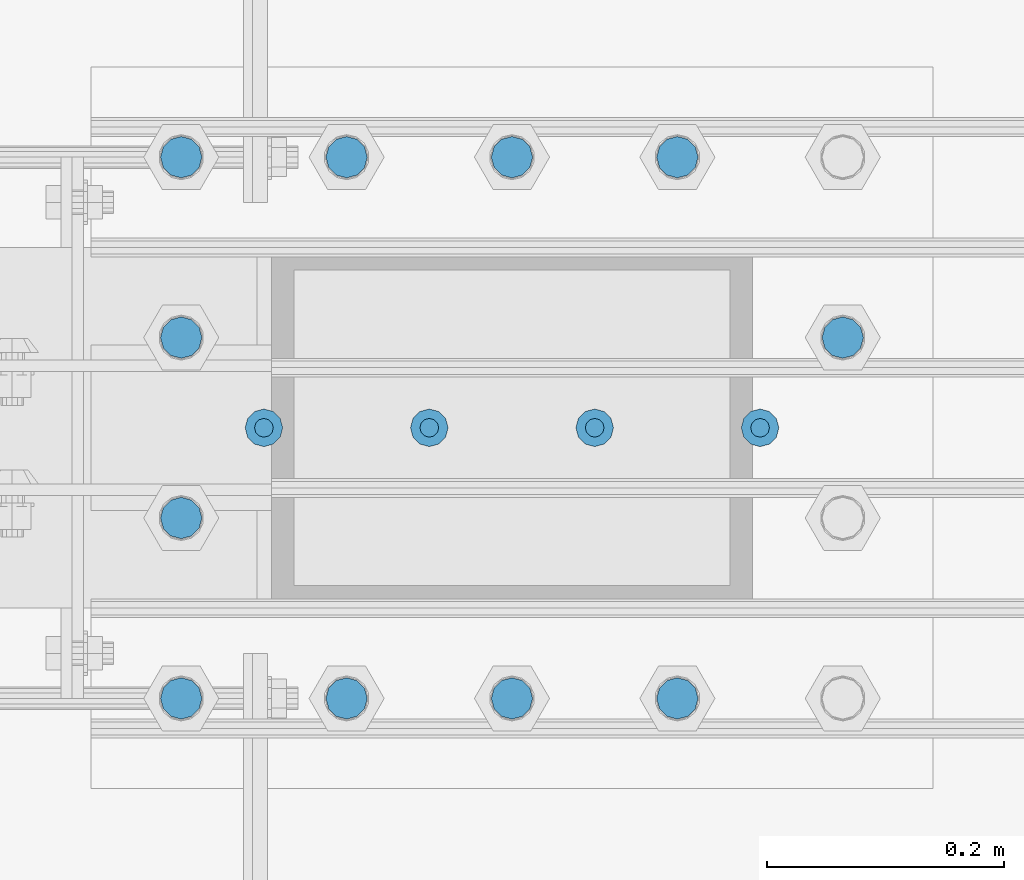
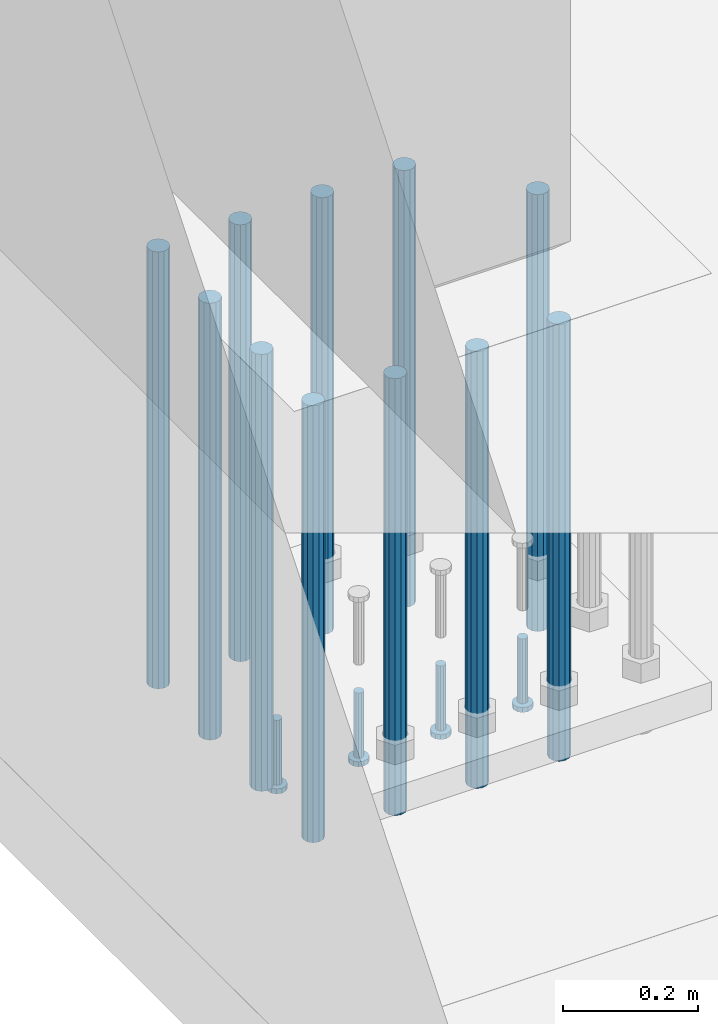
# One storey, part 1097 of 1876: 15 beams, 1 element without a shape of its own.
"""IFC2X3 building model written with IfcOpenShell, lengths in millimetres."""

import ifcopenshell
import ifcopenshell.guid

model = None  # the IFC model being written
_history = None  # IfcOwnerHistory: only IFC2X3 demands one
_inside = {}  # id of a spatial element -> (the spatial element, [elements in it])
_under = {}  # id of a project, library or spatial element -> (it, [spatial elements below it])
_declared = {}  # id of a project -> (the project, [libraries it declares])
_typed = {}  # id of a type object -> (the type object, [elements of that type])
_made_of = {}  # id of a material, layer set ... -> (it, [elements and type objects made of it])


def new_model(schema):
    """Start an empty IFC model of exactly this schema.

    Asked for "IFC4X3", IfcOpenShell would pick the latest addendum, in which some entities
    have other attributes; the version numbers below select the first issue.
    IFC2X3 requires an IfcOwnerHistory on every rooted entity: one is made here for all.
    """
    global model, _history
    if schema == "IFC4X3":
        model = ifcopenshell.file(schema_version=(4, 3, 0, 0))
    else:
        model = ifcopenshell.file(schema=schema)
    _inside.clear()
    _under.clear()
    _declared.clear()
    _typed.clear()
    _made_of.clear()
    _history = None
    if model.schema == "IFC2X3":
        org = make("IfcOrganization", Name="unknown")
        user = make(
            "IfcPersonAndOrganization",
            ThePerson=make("IfcPerson", FamilyName="unknown"),
            TheOrganization=org,
        )
        app = make(
            "IfcApplication",
            ApplicationDeveloper=org,
            Version="unknown",
            ApplicationFullName="unknown",
            ApplicationIdentifier="unknown",
        )
        _history = make(
            "IfcOwnerHistory",
            OwningUser=user,
            OwningApplication=app,
            ChangeAction="ADDED",
            CreationDate=0,
        )
    return model


def make(cls, **values):
    """One entity of the class cls with the attributes given. An attribute that is None is left unset."""
    return model.create_entity(
        cls, **{name: value for name, value in values.items() if value is not None}
    )


def rooted(cls, **values):
    """An entity with a GlobalId (a new one), such as an element, a storey or a relation."""
    return make(cls, GlobalId=ifcopenshell.guid.new(), OwnerHistory=_history, **values)


def si_unit(unit_type, name, prefix=None):
    """IfcSIUnit, for example si_unit("LENGTHUNIT", "METRE", prefix="MILLI")."""
    return make("IfcSIUnit", UnitType=unit_type, Prefix=prefix, Name=name)


def assignment(units):
    """IfcUnitAssignment: the units of a project."""
    return None if units is None else make("IfcUnitAssignment", Units=units)


def point(xyz):
    """IfcCartesianPoint."""
    return None if xyz is None else make("IfcCartesianPoint", Coordinates=xyz)


def direction(xyz):
    """IfcDirection."""
    return None if xyz is None else make("IfcDirection", DirectionRatios=xyz)


def frame(location, z_axis=None, x_axis=None):
    """IfcAxis2Placement3D, a coordinate frame: its origin and axes. An axis left out is left unset."""
    return make(
        "IfcAxis2Placement3D",
        Location=point(location),
        Axis=direction(z_axis),
        RefDirection=direction(x_axis),
    )


def origin_with_axes():
    """The frame at (0, 0, 0) with the z axis (0, 0, 1) and the x axis (1, 0, 0) written out."""
    return frame((0.0, 0.0, 0.0), z_axis=(0.0, 0.0, 1.0), x_axis=(1.0, 0.0, 0.0))


def place(relative_to, where):
    """IfcLocalPlacement: puts the frame where relative to a parent placement (None: the world)."""
    return make(
        "IfcLocalPlacement", PlacementRelTo=relative_to, RelativePlacement=where
    )


def context(
    kind, dimensions, precision=None, world=None, true_north=None, identifier=None
):
    """IfcGeometricRepresentationContext, for example the 3D "Model" context."""
    return make(
        "IfcGeometricRepresentationContext",
        ContextIdentifier=identifier,
        ContextType=kind,
        CoordinateSpaceDimension=dimensions,
        Precision=precision,
        WorldCoordinateSystem=world,
        TrueNorth=true_north,
    )


def subcontext(parent, identifier, kind, view, scale=None):
    """IfcGeometricRepresentationSubContext, for example "Body" below "Model"."""
    return make(
        "IfcGeometricRepresentationSubContext",
        ContextIdentifier=identifier,
        ContextType=kind,
        ParentContext=parent,
        TargetScale=scale,
        TargetView=view,
    )


def project(units=None, contexts=None):
    """IfcProject with its units and contexts."""
    return rooted(
        "IfcProject",
        Name="project",
        RepresentationContexts=contexts,
        UnitsInContext=assignment(units),
    )


def spatial(cls, under=None, at=None, **own):
    """A site, building, storey or space (cls), placed at a placement, below another one or the project."""
    s = rooted(cls, ObjectPlacement=at, **own)
    if under is not None:
        _under.setdefault(under.id(), (under, []))[1].append(s)
    return s


def faces_of(points, faces, orient=None, outer=None):
    """IfcFace entities. A face is a list of loops; a loop is a list of indices into points, from 0.

    orient and outer hold one flag for each loop. By default every Orientation is true, the
    first loop of a face is its IfcFaceOuterBound and the others are IfcFaceBound.
    """
    made = []
    for i, loops in enumerate(faces):
        bounds = []
        for j, loop in enumerate(loops):
            is_outer = j == 0 if outer is None else outer[i][j]
            bounds.append(
                make(
                    "IfcFaceOuterBound" if is_outer else "IfcFaceBound",
                    Bound=make("IfcPolyLoop", Polygon=[points[k] for k in loop]),
                    Orientation=True if orient is None else orient[i][j],
                )
            )
        made.append(make("IfcFace", Bounds=bounds))
    return made


def faceted_brep(points, faces, orient=None, outer=None, voids=None):
    """IfcFacetedBrep: a solid bounded by flat faces; with voids (closed shells), ...WithVoids."""
    shared = [point(p) for p in points]
    hull = make("IfcClosedShell", CfsFaces=faces_of(shared, faces, orient, outer))
    if voids is None:
        return make("IfcFacetedBrep", Outer=hull)
    return make(
        "IfcFacetedBrepWithVoids",
        Outer=hull,
        Voids=[
            make(cls, CfsFaces=faces_of(shared, fs, o, b)) for cls, fs, o, b in voids
        ],
    )


def shape(context_of_items, identifier, shape_type, items):
    """IfcShapeRepresentation: the items that make up one representation, for example the "Body"."""
    return make(
        "IfcShapeRepresentation",
        ContextOfItems=context_of_items,
        RepresentationIdentifier=identifier,
        RepresentationType=shape_type,
        Items=items,
    )


def material(Name=None, Category=None):
    """IfcMaterial."""
    return make("IfcMaterial", Name=Name, Category=Category)


def made_of(thing, what):
    """Note that an element or type object is made of a material, layer set ...; save() writes the relation."""
    if what is not None:
        _made_of.setdefault(what.id(), (what, []))[1].append(thing)
    return thing


def type_object(cls, material=None, **own):
    """A type object (cls), such as IfcWallType, which elements share."""
    return made_of(rooted(cls, **own), material)


def element(
    cls,
    number,
    at=None,
    inside=None,
    cuts=None,
    type_object=None,
    material=None,
    context=None,
    identifier="Body",
    shape_type=None,
    held_by="IfcProductDefinitionShape",
    body=None,
    shapes=None,
    **own,
):
    """One element of the class cls, such as IfcWall. Its Tag is "e" and its number.

    at: its placement. inside: the storey or other place that contains it. cuts: it is an
    opening in that element (IfcRelVoidsElement). A single representation is given by context,
    identifier, shape_type and body (its items); several are given by shapes. held_by: the class
    of the entity that holds the representations. save() writes the other relations.
    """
    e = rooted(cls, Tag="e%d" % number, ObjectPlacement=at, **own)
    if body is not None:
        shapes = [shape(context, identifier, shape_type, body)]
    if shapes is not None:
        e.Representation = make(held_by, Representations=shapes)
    if inside is not None:
        _inside.setdefault(inside.id(), (inside, []))[1].append(e)
    if cuts is not None:
        rooted(
            "IfcRelVoidsElement", RelatingBuildingElement=cuts, RelatedOpeningElement=e
        )
    if type_object is not None:
        _typed.setdefault(type_object.id(), (type_object, []))[1].append(e)
    return made_of(e, material)


def aggregate(whole, parts):
    """IfcRelAggregates: a whole, such as a stair, and the parts it consists of."""
    return rooted("IfcRelAggregates", RelatingObject=whole, RelatedObjects=parts)


def save(model, path):
    """Write the relations noted so far, then the file.

    IfcRelAggregates (storeys below a building ...), IfcRelContainedInSpatialStructure (elements
    in a storey), IfcRelDefinesByType, IfcRelAssociatesMaterial and IfcRelDeclares: one each for
    every whole, place, type object, material and project.
    """
    for whole, parts in _under.values():
        aggregate(whole, parts)
    for where, things in _inside.values():
        rooted(
            "IfcRelContainedInSpatialStructure",
            RelatedElements=things,
            RelatingStructure=where,
        )
    for kind, things in _typed.values():
        rooted("IfcRelDefinesByType", RelatedObjects=things, RelatingType=kind)
    for what, things in _made_of.values():
        rooted("IfcRelAssociatesMaterial", RelatedObjects=things, RelatingMaterial=what)
    for by, libraries in _declared.values():
        rooted("IfcRelDeclares", RelatingContext=by, RelatedDefinitions=libraries)
    model.write(path)


model = new_model("IFC2X3")

# Units and contexts
model_context = context("Model", 3, precision=1e-05, world=origin_with_axes())
body_context = subcontext(model_context, "Body", "Model", "MODEL_VIEW")
ifc_project = project(units=[si_unit("LENGTHUNIT", "METRE", prefix="MILLI"), si_unit("AREAUNIT", "SQUARE_METRE"), si_unit("VOLUMEUNIT", "CUBIC_METRE"), si_unit("MASSUNIT", "GRAM", prefix="KILO"), si_unit("TIMEUNIT", "SECOND"), si_unit("PLANEANGLEUNIT", "RADIAN"), si_unit("SOLIDANGLEUNIT", "STERADIAN"), si_unit("THERMODYNAMICTEMPERATUREUNIT", "DEGREE_CELSIUS"), si_unit("LUMINOUSINTENSITYUNIT", "LUMEN")], contexts=[model_context])

# Site, building, storey
site_placement = place(None, origin_with_axes())
site = spatial("IfcSite", under=ifc_project, at=site_placement, CompositionType="ELEMENT")
building_placement = place(site_placement, origin_with_axes())
building = spatial("IfcBuilding", under=site, at=building_placement, Name="Undefined", CompositionType="ELEMENT")
storey_placement = place(building_placement, origin_with_axes())
storey = spatial("IfcBuildingStorey", under=building, at=storey_placement, Name="Undefined", CompositionType="ELEMENT", Elevation=0.0)

# Assembly, beams
assembly_placement = place(storey_placement, origin_with_axes())
assembly = element("IfcElementAssembly", 1, at=assembly_placement, inside=storey, Name="PLATE", AssemblyPlace="NOTDEFINED", PredefinedType="RIGID_FRAME")
ifc_material_1 = material(Name="STEEL/A108")
beam_type_1 = type_object("IfcBeamType", Name="5/8-DIA_HEADED ANCHOR STUD", PredefinedType="NOTDEFINED")
beam_1_placement = place(assembly_placement, frame((441.324993896483, -14427.2, -787.400000000001), z_axis=(1.0, 0.0, 0.0), x_axis=(0.0, 0.0, -1.0)))
beam_1 = element("IfcBeam", 2, at=beam_1_placement, type_object=beam_type_1, material=ifc_material_1, Name="HEADED ANCHOR STUD", ObjectType="5/8-DIA_HEADED ANCHOR STUD", context=body_context, shape_type="Brep", body=[
    faceted_brep([(0.0, -7.94000005722046, 0.0), (0.0, -6.86999988555908, -3.97000002861023), (116.84, -6.86999988555908, -3.97000002861023), (116.84, -7.94000005722046, 0.0), (0.0, -3.97000002861023, -6.86999988555908), (116.84, -3.97000002861023, -6.86999988555908), (0.0, 0.0, -7.94000005722046), (116.84, 0.0, -7.94000005722046), (0.0, 3.97000002861023, -6.86999988555908), (116.84, 3.97000002861023, -6.86999988555908), (0.0, 6.86999988555908, -3.97000002861023), (116.84, 6.86999988555908, -3.97000002861023), (0.0, 7.94000005722046, 0.0), (116.84, 7.94000005722046, 0.0), (0.0, 6.86999988555908, 3.97000002861023), (116.84, 6.86999988555908, 3.97000002861023), (0.0, 3.97000002861023, 6.86999988555908), (116.84, 3.97000002861023, 6.86999988555908), (0.0, 0.0, 7.94000005722046), (116.84, 0.0, 7.94000005722046), (0.0, -3.97000002861023, 6.86999988555908), (116.84, -3.97000002861023, 6.86999988555908), (0.0, -6.86999988555908, 3.97000002861023), (116.84, -6.86999988555908, 3.97000002861023), (118.11, -13.75, -7.94000005722046), (118.11, -15.8800001144409, 0.0), (118.11, -7.94000005722046, -13.75), (118.11, 0.0, -15.8800001144409), (118.11, 7.94000005722046, -13.75), (118.11, 13.75, -7.94000005722046), (118.11, 15.8800001144409, 0.0), (118.11, 13.75, 7.94000005722046), (118.11, 7.94000005722046, 13.75), (118.11, 0.0, 15.8800001144409), (118.11, -7.94000005722046, 13.75), (118.11, -13.75, 7.94000005722046), (127.0, -13.75, -7.94000005722046), (127.0, -15.8800001144409, 0.0), (127.0, -7.94000005722046, -13.75), (127.0, 0.0, -15.8800001144409), (127.0, 7.94000005722046, -13.75), (127.0, 13.75, -7.94000005722046), (127.0, 15.8800001144409, 0.0), (127.0, 13.75, 7.94000005722046), (127.0, 7.94000005722046, 13.75), (127.0, 0.0, 15.8800001144409), (127.0, -7.94000005722046, 13.75), (127.0, -13.75, 7.94000005722046)], [[[0, 1, 2, 3]], [[1, 4, 5, 2]], [[4, 6, 7, 5]], [[6, 8, 9, 7]], [[8, 10, 11, 9]], [[10, 12, 13, 11]], [[12, 14, 15, 13]], [[14, 16, 17, 15]], [[16, 18, 19, 17]], [[18, 20, 21, 19]], [[20, 22, 23, 21]], [[22, 0, 3, 23]], [[22, 20, 18, 16, 14, 12, 10, 8, 6, 4, 1, 0]], [[3, 2, 24, 25]], [[2, 5, 26, 24]], [[5, 7, 27, 26]], [[7, 9, 28, 27]], [[9, 11, 29, 28]], [[11, 13, 30, 29]], [[13, 15, 31, 30]], [[15, 17, 32, 31]], [[17, 19, 33, 32]], [[19, 21, 34, 33]], [[21, 23, 35, 34]], [[23, 3, 25, 35]], [[25, 24, 36, 37]], [[24, 26, 38, 36]], [[26, 27, 39, 38]], [[27, 28, 40, 39]], [[28, 29, 41, 40]], [[29, 30, 42, 41]], [[30, 31, 43, 42]], [[31, 32, 44, 43]], [[32, 33, 45, 44]], [[33, 34, 46, 45]], [[34, 35, 47, 46]], [[35, 25, 37, 47]], [[38, 39, 40, 41, 42, 43, 44, 45, 46, 47, 37, 36]]]),
])
beam_2_placement = place(assembly_placement, frame((301.624987792968, -14427.2, -787.400000000001), z_axis=(1.0, 0.0, 0.0), x_axis=(0.0, 0.0, -1.0)))
beam_2 = element("IfcBeam", 3, at=beam_2_placement, type_object=beam_type_1, material=ifc_material_1, Name="HEADED ANCHOR STUD", ObjectType="5/8-DIA_HEADED ANCHOR STUD", context=body_context, shape_type="Brep", body=[
    faceted_brep([(0.0, -7.94000005722046, 0.0), (0.0, -6.86999988555908, -3.97000002861023), (116.84, -6.86999988555908, -3.97000002861023), (116.84, -7.94000005722046, 0.0), (0.0, -3.97000002861023, -6.86999988555908), (116.84, -3.97000002861023, -6.86999988555908), (0.0, 0.0, -7.94000005722046), (116.84, 0.0, -7.94000005722046), (0.0, 3.97000002861023, -6.86999988555908), (116.84, 3.97000002861023, -6.86999988555908), (0.0, 6.86999988555908, -3.97000002861023), (116.84, 6.86999988555908, -3.97000002861023), (0.0, 7.94000005722046, 0.0), (116.84, 7.94000005722046, 0.0), (0.0, 6.86999988555908, 3.97000002861023), (116.84, 6.86999988555908, 3.97000002861023), (0.0, 3.97000002861023, 6.86999988555908), (116.84, 3.97000002861023, 6.86999988555908), (0.0, 0.0, 7.94000005722046), (116.84, 0.0, 7.94000005722046), (0.0, -3.97000002861023, 6.86999988555908), (116.84, -3.97000002861023, 6.86999988555908), (0.0, -6.86999988555908, 3.97000002861023), (116.84, -6.86999988555908, 3.97000002861023), (118.11, -13.75, -7.94000005722046), (118.11, -15.8800001144409, 0.0), (118.11, -7.94000005722046, -13.75), (118.11, 0.0, -15.8800001144409), (118.11, 7.94000005722046, -13.75), (118.11, 13.75, -7.94000005722046), (118.11, 15.8800001144409, 0.0), (118.11, 13.75, 7.94000005722046), (118.11, 7.94000005722046, 13.75), (118.11, 0.0, 15.8800001144409), (118.11, -7.94000005722046, 13.75), (118.11, -13.75, 7.94000005722046), (127.0, -13.75, -7.94000005722046), (127.0, -15.8800001144409, 0.0), (127.0, -7.94000005722046, -13.75), (127.0, 0.0, -15.8800001144409), (127.0, 7.94000005722046, -13.75), (127.0, 13.75, -7.94000005722046), (127.0, 15.8800001144409, 0.0), (127.0, 13.75, 7.94000005722046), (127.0, 7.94000005722046, 13.75), (127.0, 0.0, 15.8800001144409), (127.0, -7.94000005722046, 13.75), (127.0, -13.75, 7.94000005722046)], [[[0, 1, 2, 3]], [[1, 4, 5, 2]], [[4, 6, 7, 5]], [[6, 8, 9, 7]], [[8, 10, 11, 9]], [[10, 12, 13, 11]], [[12, 14, 15, 13]], [[14, 16, 17, 15]], [[16, 18, 19, 17]], [[18, 20, 21, 19]], [[20, 22, 23, 21]], [[22, 0, 3, 23]], [[22, 20, 18, 16, 14, 12, 10, 8, 6, 4, 1, 0]], [[3, 2, 24, 25]], [[2, 5, 26, 24]], [[5, 7, 27, 26]], [[7, 9, 28, 27]], [[9, 11, 29, 28]], [[11, 13, 30, 29]], [[13, 15, 31, 30]], [[15, 17, 32, 31]], [[17, 19, 33, 32]], [[19, 21, 34, 33]], [[21, 23, 35, 34]], [[23, 3, 25, 35]], [[25, 24, 36, 37]], [[24, 26, 38, 36]], [[26, 27, 39, 38]], [[27, 28, 40, 39]], [[28, 29, 41, 40]], [[29, 30, 42, 41]], [[30, 31, 43, 42]], [[31, 32, 44, 43]], [[32, 33, 45, 44]], [[33, 34, 46, 45]], [[34, 35, 47, 46]], [[35, 25, 37, 47]], [[38, 39, 40, 41, 42, 43, 44, 45, 46, 47, 37, 36]]]),
])
beam_3_placement = place(assembly_placement, frame((161.924987792968, -14427.2, -787.400000000001), z_axis=(1.0, 0.0, 0.0), x_axis=(0.0, 0.0, -1.0)))
beam_3 = element("IfcBeam", 4, at=beam_3_placement, type_object=beam_type_1, material=ifc_material_1, Name="HEADED ANCHOR STUD", ObjectType="5/8-DIA_HEADED ANCHOR STUD", context=body_context, shape_type="Brep", body=[
    faceted_brep([(0.0, -7.94000005722046, 0.0), (0.0, -6.86999988555908, -3.97000002861023), (116.84, -6.86999988555908, -3.97000002861023), (116.84, -7.94000005722046, 0.0), (0.0, -3.97000002861023, -6.86999988555908), (116.84, -3.97000002861023, -6.86999988555908), (0.0, 0.0, -7.94000005722046), (116.84, 0.0, -7.94000005722046), (0.0, 3.97000002861023, -6.86999988555908), (116.84, 3.97000002861023, -6.86999988555908), (0.0, 6.86999988555908, -3.97000002861023), (116.84, 6.86999988555908, -3.97000002861023), (0.0, 7.94000005722046, 0.0), (116.84, 7.94000005722046, 0.0), (0.0, 6.86999988555908, 3.97000002861023), (116.84, 6.86999988555908, 3.97000002861023), (0.0, 3.97000002861023, 6.86999988555908), (116.84, 3.97000002861023, 6.86999988555908), (0.0, 0.0, 7.94000005722046), (116.84, 0.0, 7.94000005722046), (0.0, -3.97000002861023, 6.86999988555908), (116.84, -3.97000002861023, 6.86999988555908), (0.0, -6.86999988555908, 3.97000002861023), (116.84, -6.86999988555908, 3.97000002861023), (118.11, -13.75, -7.94000005722046), (118.11, -15.8800001144409, 0.0), (118.11, -7.94000005722046, -13.75), (118.11, 0.0, -15.8800001144409), (118.11, 7.94000005722046, -13.75), (118.11, 13.75, -7.94000005722046), (118.11, 15.8800001144409, 0.0), (118.11, 13.75, 7.94000005722046), (118.11, 7.94000005722046, 13.75), (118.11, 0.0, 15.8800001144409), (118.11, -7.94000005722046, 13.75), (118.11, -13.75, 7.94000005722046), (127.0, -13.75, -7.94000005722046), (127.0, -15.8800001144409, 0.0), (127.0, -7.94000005722046, -13.75), (127.0, 0.0, -15.8800001144409), (127.0, 7.94000005722046, -13.75), (127.0, 13.75, -7.94000005722046), (127.0, 15.8800001144409, 0.0), (127.0, 13.75, 7.94000005722046), (127.0, 7.94000005722046, 13.75), (127.0, 0.0, 15.8800001144409), (127.0, -7.94000005722046, 13.75), (127.0, -13.75, 7.94000005722046)], [[[0, 1, 2, 3]], [[1, 4, 5, 2]], [[4, 6, 7, 5]], [[6, 8, 9, 7]], [[8, 10, 11, 9]], [[10, 12, 13, 11]], [[12, 14, 15, 13]], [[14, 16, 17, 15]], [[16, 18, 19, 17]], [[18, 20, 21, 19]], [[20, 22, 23, 21]], [[22, 0, 3, 23]], [[22, 20, 18, 16, 14, 12, 10, 8, 6, 4, 1, 0]], [[3, 2, 24, 25]], [[2, 5, 26, 24]], [[5, 7, 27, 26]], [[7, 9, 28, 27]], [[9, 11, 29, 28]], [[11, 13, 30, 29]], [[13, 15, 31, 30]], [[15, 17, 32, 31]], [[17, 19, 33, 32]], [[19, 21, 34, 33]], [[21, 23, 35, 34]], [[23, 3, 25, 35]], [[25, 24, 36, 37]], [[24, 26, 38, 36]], [[26, 27, 39, 38]], [[27, 28, 40, 39]], [[28, 29, 41, 40]], [[29, 30, 42, 41]], [[30, 31, 43, 42]], [[31, 32, 44, 43]], [[32, 33, 45, 44]], [[33, 34, 46, 45]], [[34, 35, 47, 46]], [[35, 25, 37, 47]], [[38, 39, 40, 41, 42, 43, 44, 45, 46, 47, 37, 36]]]),
])
beam_4_placement = place(assembly_placement, frame((22.2249877929677, -14427.2, -787.400000000001), z_axis=(1.0, 0.0, 0.0), x_axis=(0.0, 0.0, -1.0)))
beam_4 = element("IfcBeam", 5, at=beam_4_placement, type_object=beam_type_1, material=ifc_material_1, Name="HEADED ANCHOR STUD", ObjectType="5/8-DIA_HEADED ANCHOR STUD", context=body_context, shape_type="Brep", body=[
    faceted_brep([(0.0, -7.94000005722046, 0.0), (0.0, -6.86999988555908, -3.97000002861023), (116.84, -6.86999988555908, -3.97000002861023), (116.84, -7.94000005722046, 0.0), (0.0, -3.97000002861023, -6.86999988555908), (116.84, -3.97000002861023, -6.86999988555908), (0.0, 0.0, -7.94000005722046), (116.84, 0.0, -7.94000005722046), (0.0, 3.97000002861023, -6.86999988555908), (116.84, 3.97000002861023, -6.86999988555908), (0.0, 6.86999988555908, -3.97000002861023), (116.84, 6.86999988555908, -3.97000002861023), (0.0, 7.94000005722046, 0.0), (116.84, 7.94000005722046, 0.0), (0.0, 6.86999988555908, 3.97000002861023), (116.84, 6.86999988555908, 3.97000002861023), (0.0, 3.97000002861023, 6.86999988555908), (116.84, 3.97000002861023, 6.86999988555908), (0.0, 0.0, 7.94000005722046), (116.84, 0.0, 7.94000005722046), (0.0, -3.97000002861023, 6.86999988555908), (116.84, -3.97000002861023, 6.86999988555908), (0.0, -6.86999988555908, 3.97000002861023), (116.84, -6.86999988555908, 3.97000002861023), (118.11, -13.75, -7.94000005722046), (118.11, -15.8800001144409, 0.0), (118.11, -7.94000005722046, -13.75), (118.11, 0.0, -15.8800001144409), (118.11, 7.94000005722046, -13.75), (118.11, 13.75, -7.94000005722046), (118.11, 15.8800001144409, 0.0), (118.11, 13.75, 7.94000005722046), (118.11, 7.94000005722046, 13.75), (118.11, 0.0, 15.8800001144409), (118.11, -7.94000005722046, 13.75), (118.11, -13.75, 7.94000005722046), (127.0, -13.75, -7.94000005722046), (127.0, -15.8800001144409, 0.0), (127.0, -7.94000005722046, -13.75), (127.0, 0.0, -15.8800001144409), (127.0, 7.94000005722046, -13.75), (127.0, 13.75, -7.94000005722046), (127.0, 15.8800001144409, 0.0), (127.0, 13.75, 7.94000005722046), (127.0, 7.94000005722046, 13.75), (127.0, 0.0, 15.8800001144409), (127.0, -7.94000005722046, 13.75), (127.0, -13.75, 7.94000005722046)], [[[0, 1, 2, 3]], [[1, 4, 5, 2]], [[4, 6, 7, 5]], [[6, 8, 9, 7]], [[8, 10, 11, 9]], [[10, 12, 13, 11]], [[12, 14, 15, 13]], [[14, 16, 17, 15]], [[16, 18, 19, 17]], [[18, 20, 21, 19]], [[20, 22, 23, 21]], [[22, 0, 3, 23]], [[22, 20, 18, 16, 14, 12, 10, 8, 6, 4, 1, 0]], [[3, 2, 24, 25]], [[2, 5, 26, 24]], [[5, 7, 27, 26]], [[7, 9, 28, 27]], [[9, 11, 29, 28]], [[11, 13, 30, 29]], [[13, 15, 31, 30]], [[15, 17, 32, 31]], [[17, 19, 33, 32]], [[19, 21, 34, 33]], [[21, 23, 35, 34]], [[23, 3, 25, 35]], [[25, 24, 36, 37]], [[24, 26, 38, 36]], [[26, 27, 39, 38]], [[27, 28, 40, 39]], [[28, 29, 41, 40]], [[29, 30, 42, 41]], [[30, 31, 43, 42]], [[31, 32, 44, 43]], [[32, 33, 45, 44]], [[33, 34, 46, 45]], [[34, 35, 47, 46]], [[35, 25, 37, 47]], [[38, 39, 40, 41, 42, 43, 44, 45, 46, 47, 37, 36]]]),
])
ifc_material_2 = material(Name="STEEL/F1554-55, S1")
beam_type_2 = type_object("IfcBeamType", PredefinedType="NOTDEFINED")
beam_5_placement = place(assembly_placement, frame((371.474987792968, -14655.7999755859, -50.7999999999993), z_axis=(0.0, -1.0, 0.0), x_axis=(0.0, 0.0, -1.0)))
beam_5 = element("IfcBeam", 6, at=beam_5_placement, type_object=beam_type_2, material=ifc_material_2, Name="WELDED HEADED STUD", context=body_context, shape_type="Brep", body=[
    faceted_brep([(0.0, -17.4625, 0.0), (0.0, -15.1229686135857, -8.73125000000073), (787.399999999999, -15.1229686135857, -8.73125000000073), (787.399999999999, -17.4625, 0.0), (0.0, -8.73124999999999, -15.1229686135848), (787.399999999999, -8.73124999999999, -15.1229686135848), (0.0, 0.0, -17.4625000000015), (787.399999999999, 0.0, -17.4625000000015), (0.0, 8.73124999999999, -15.1229686135848), (787.399999999999, 8.73124999999999, -15.1229686135848), (0.0, 15.1229686135858, -8.73125000000073), (787.399999999999, 15.1229686135858, -8.73125000000073), (0.0, 17.4625, 0.0), (787.399999999999, 17.4625, 0.0), (0.0, 15.1229686135858, 8.73125000000073), (787.399999999999, 15.1229686135858, 8.73125000000073), (0.0, 8.73124999999999, 15.1229686135848), (787.399999999999, 8.73124999999999, 15.1229686135848), (0.0, 0.0, 17.4625000000015), (787.399999999999, 0.0, 17.4625000000015), (0.0, -8.73124999999999, 15.1229686135848), (787.399999999999, -8.73124999999999, 15.1229686135848), (0.0, -15.1229686135858, 8.73125000000073), (787.399999999999, -15.1229686135858, 8.73125000000073)], [[[0, 1, 2, 3]], [[1, 4, 5, 2]], [[4, 6, 7, 5]], [[6, 8, 9, 7]], [[8, 10, 11, 9]], [[10, 12, 13, 11]], [[12, 14, 15, 13]], [[14, 16, 17, 15]], [[16, 18, 19, 17]], [[18, 20, 21, 19]], [[20, 22, 23, 21]], [[22, 0, 3, 23]], [[5, 7, 9, 11, 13, 15, 17, 19, 21, 23, 3, 2]], [[22, 20, 18, 16, 14, 12, 10, 8, 6, 4, 1, 0]]]),
])
beam_6_placement = place(assembly_placement, frame((231.774987792968, -14655.7999755859, -50.7999999999993), z_axis=(0.0, -1.0, 0.0), x_axis=(0.0, 0.0, -1.0)))
beam_6 = element("IfcBeam", 7, at=beam_6_placement, type_object=beam_type_2, material=ifc_material_2, Name="WELDED HEADED STUD", context=body_context, shape_type="Brep", body=[
    faceted_brep([(0.0, -17.4625, 0.0), (0.0, -15.1229686135857, -8.73125000000073), (787.399999999999, -15.1229686135857, -8.73125000000073), (787.399999999999, -17.4625, 0.0), (0.0, -8.73124999999999, -15.1229686135848), (787.399999999999, -8.73124999999999, -15.1229686135848), (0.0, 0.0, -17.4625000000015), (787.399999999999, 0.0, -17.4625000000015), (0.0, 8.73124999999999, -15.1229686135848), (787.399999999999, 8.73124999999999, -15.1229686135848), (0.0, 15.1229686135858, -8.73125000000073), (787.399999999999, 15.1229686135858, -8.73125000000073), (0.0, 17.4625, 0.0), (787.399999999999, 17.4625, 0.0), (0.0, 15.1229686135858, 8.73125000000073), (787.399999999999, 15.1229686135858, 8.73125000000073), (0.0, 8.73124999999999, 15.1229686135848), (787.399999999999, 8.73124999999999, 15.1229686135848), (0.0, 0.0, 17.4625000000015), (787.399999999999, 0.0, 17.4625000000015), (0.0, -8.73124999999999, 15.1229686135848), (787.399999999999, -8.73124999999999, 15.1229686135848), (0.0, -15.1229686135858, 8.73125000000073), (787.399999999999, -15.1229686135858, 8.73125000000073)], [[[0, 1, 2, 3]], [[1, 4, 5, 2]], [[4, 6, 7, 5]], [[6, 8, 9, 7]], [[8, 10, 11, 9]], [[10, 12, 13, 11]], [[12, 14, 15, 13]], [[14, 16, 17, 15]], [[16, 18, 19, 17]], [[18, 20, 21, 19]], [[20, 22, 23, 21]], [[22, 0, 3, 23]], [[5, 7, 9, 11, 13, 15, 17, 19, 21, 23, 3, 2]], [[22, 20, 18, 16, 14, 12, 10, 8, 6, 4, 1, 0]]]),
])
beam_7_placement = place(assembly_placement, frame((92.0749877929678, -14655.7999755859, -50.7999999999993), z_axis=(0.0, -1.0, 0.0), x_axis=(0.0, 0.0, -1.0)))
beam_7 = element("IfcBeam", 8, at=beam_7_placement, type_object=beam_type_2, material=ifc_material_2, Name="WELDED HEADED STUD", context=body_context, shape_type="Brep", body=[
    faceted_brep([(0.0, -17.4625, 0.0), (0.0, -15.1229686135857, -8.73125000000073), (787.399999999999, -15.1229686135857, -8.73125000000073), (787.399999999999, -17.4625, 0.0), (0.0, -8.73124999999999, -15.1229686135848), (787.399999999999, -8.73124999999999, -15.1229686135848), (0.0, 0.0, -17.4625000000015), (787.399999999999, 0.0, -17.4625000000015), (0.0, 8.73124999999999, -15.1229686135848), (787.399999999999, 8.73124999999999, -15.1229686135848), (0.0, 15.1229686135858, -8.73125000000073), (787.399999999999, 15.1229686135858, -8.73125000000073), (0.0, 17.4625, 0.0), (787.399999999999, 17.4625, 0.0), (0.0, 15.1229686135858, 8.73125000000073), (787.399999999999, 15.1229686135858, 8.73125000000073), (0.0, 8.73124999999999, 15.1229686135848), (787.399999999999, 8.73124999999999, 15.1229686135848), (0.0, 0.0, 17.4625000000015), (787.399999999999, 0.0, 17.4625000000015), (0.0, -8.73124999999999, 15.1229686135848), (787.399999999999, -8.73124999999999, 15.1229686135848), (0.0, -15.1229686135858, 8.73125000000073), (787.399999999999, -15.1229686135858, 8.73125000000073)], [[[0, 1, 2, 3]], [[1, 4, 5, 2]], [[4, 6, 7, 5]], [[6, 8, 9, 7]], [[8, 10, 11, 9]], [[10, 12, 13, 11]], [[12, 14, 15, 13]], [[14, 16, 17, 15]], [[16, 18, 19, 17]], [[18, 20, 21, 19]], [[20, 22, 23, 21]], [[22, 0, 3, 23]], [[5, 7, 9, 11, 13, 15, 17, 19, 21, 23, 3, 2]], [[22, 20, 18, 16, 14, 12, 10, 8, 6, 4, 1, 0]]]),
])
beam_8_placement = place(assembly_placement, frame((371.474987792968, -14198.6, -50.7999999999993), z_axis=(0.0, -1.0, 0.0), x_axis=(0.0, 0.0, -1.0)))
beam_8 = element("IfcBeam", 9, at=beam_8_placement, type_object=beam_type_2, material=ifc_material_2, Name="WELDED HEADED STUD", context=body_context, shape_type="Brep", body=[
    faceted_brep([(0.0, -17.4625, 0.0), (0.0, -15.1229686135857, -8.73125000000073), (787.399999999999, -15.1229686135857, -8.73125000000073), (787.399999999999, -17.4625, 0.0), (0.0, -8.73124999999999, -15.1229686135848), (787.399999999999, -8.73124999999999, -15.1229686135848), (0.0, 0.0, -17.4625000000015), (787.399999999999, 0.0, -17.4625000000015), (0.0, 8.73124999999999, -15.1229686135848), (787.399999999999, 8.73124999999999, -15.1229686135848), (0.0, 15.1229686135858, -8.73125000000073), (787.399999999999, 15.1229686135858, -8.73125000000073), (0.0, 17.4625, 0.0), (787.399999999999, 17.4625, 0.0), (0.0, 15.1229686135858, 8.73125000000073), (787.399999999999, 15.1229686135858, 8.73125000000073), (0.0, 8.73124999999999, 15.1229686135848), (787.399999999999, 8.73124999999999, 15.1229686135848), (0.0, 0.0, 17.4625000000015), (787.399999999999, 0.0, 17.4625000000015), (0.0, -8.73124999999999, 15.1229686135848), (787.399999999999, -8.73124999999999, 15.1229686135848), (0.0, -15.1229686135858, 8.73125000000073), (787.399999999999, -15.1229686135858, 8.73125000000073)], [[[0, 1, 2, 3]], [[1, 4, 5, 2]], [[4, 6, 7, 5]], [[6, 8, 9, 7]], [[8, 10, 11, 9]], [[10, 12, 13, 11]], [[12, 14, 15, 13]], [[14, 16, 17, 15]], [[16, 18, 19, 17]], [[18, 20, 21, 19]], [[20, 22, 23, 21]], [[22, 0, 3, 23]], [[5, 7, 9, 11, 13, 15, 17, 19, 21, 23, 3, 2]], [[22, 20, 18, 16, 14, 12, 10, 8, 6, 4, 1, 0]]]),
])
beam_9_placement = place(assembly_placement, frame((231.774987792968, -14198.6, -50.7999999999993), z_axis=(0.0, -1.0, 0.0), x_axis=(0.0, 0.0, -1.0)))
beam_9 = element("IfcBeam", 10, at=beam_9_placement, type_object=beam_type_2, material=ifc_material_2, Name="WELDED HEADED STUD", context=body_context, shape_type="Brep", body=[
    faceted_brep([(0.0, -17.4625, 0.0), (0.0, -15.1229686135857, -8.73125000000073), (787.399999999999, -15.1229686135857, -8.73125000000073), (787.399999999999, -17.4625, 0.0), (0.0, -8.73124999999999, -15.1229686135848), (787.399999999999, -8.73124999999999, -15.1229686135848), (0.0, 0.0, -17.4625000000015), (787.399999999999, 0.0, -17.4625000000015), (0.0, 8.73124999999999, -15.1229686135848), (787.399999999999, 8.73124999999999, -15.1229686135848), (0.0, 15.1229686135858, -8.73125000000073), (787.399999999999, 15.1229686135858, -8.73125000000073), (0.0, 17.4625, 0.0), (787.399999999999, 17.4625, 0.0), (0.0, 15.1229686135858, 8.73125000000073), (787.399999999999, 15.1229686135858, 8.73125000000073), (0.0, 8.73124999999999, 15.1229686135848), (787.399999999999, 8.73124999999999, 15.1229686135848), (0.0, 0.0, 17.4625000000015), (787.399999999999, 0.0, 17.4625000000015), (0.0, -8.73124999999999, 15.1229686135848), (787.399999999999, -8.73124999999999, 15.1229686135848), (0.0, -15.1229686135858, 8.73125000000073), (787.399999999999, -15.1229686135858, 8.73125000000073)], [[[0, 1, 2, 3]], [[1, 4, 5, 2]], [[4, 6, 7, 5]], [[6, 8, 9, 7]], [[8, 10, 11, 9]], [[10, 12, 13, 11]], [[12, 14, 15, 13]], [[14, 16, 17, 15]], [[16, 18, 19, 17]], [[18, 20, 21, 19]], [[20, 22, 23, 21]], [[22, 0, 3, 23]], [[5, 7, 9, 11, 13, 15, 17, 19, 21, 23, 3, 2]], [[22, 20, 18, 16, 14, 12, 10, 8, 6, 4, 1, 0]]]),
])
beam_10_placement = place(assembly_placement, frame((92.0749877929677, -14198.6, -50.7999999999993), z_axis=(0.0, -1.0, 0.0), x_axis=(0.0, 0.0, -1.0)))
beam_10 = element("IfcBeam", 11, at=beam_10_placement, type_object=beam_type_2, material=ifc_material_2, Name="WELDED HEADED STUD", context=body_context, shape_type="Brep", body=[
    faceted_brep([(0.0, -17.4625, 0.0), (0.0, -15.1229686135857, -8.73125000000073), (787.399999999999, -15.1229686135857, -8.73125000000073), (787.399999999999, -17.4625, 0.0), (0.0, -8.73124999999999, -15.1229686135848), (787.399999999999, -8.73124999999999, -15.1229686135848), (0.0, 0.0, -17.4625000000015), (787.399999999999, 0.0, -17.4625000000015), (0.0, 8.73124999999999, -15.1229686135848), (787.399999999999, 8.73124999999999, -15.1229686135848), (0.0, 15.1229686135858, -8.73125000000073), (787.399999999999, 15.1229686135858, -8.73125000000073), (0.0, 17.4625, 0.0), (787.399999999999, 17.4625, 0.0), (0.0, 15.1229686135858, 8.73125000000073), (787.399999999999, 15.1229686135858, 8.73125000000073), (0.0, 8.73124999999999, 15.1229686135848), (787.399999999999, 8.73124999999999, 15.1229686135848), (0.0, 0.0, 17.4625000000015), (787.399999999999, 0.0, 17.4625000000015), (0.0, -8.73124999999999, 15.1229686135848), (787.399999999999, -8.73124999999999, 15.1229686135848), (0.0, -15.1229686135858, 8.73125000000073), (787.399999999999, -15.1229686135858, 8.73125000000073)], [[[0, 1, 2, 3]], [[1, 4, 5, 2]], [[4, 6, 7, 5]], [[6, 8, 9, 7]], [[8, 10, 11, 9]], [[10, 12, 13, 11]], [[12, 14, 15, 13]], [[14, 16, 17, 15]], [[16, 18, 19, 17]], [[18, 20, 21, 19]], [[20, 22, 23, 21]], [[22, 0, 3, 23]], [[5, 7, 9, 11, 13, 15, 17, 19, 21, 23, 3, 2]], [[22, 20, 18, 16, 14, 12, 10, 8, 6, 4, 1, 0]]]),
])
beam_11_placement = place(assembly_placement, frame((-47.6250122070323, -14350.999991862, -50.7999999999993), z_axis=(0.0, -1.0, 0.0), x_axis=(0.0, 0.0, -1.0)))
beam_11 = element("IfcBeam", 12, at=beam_11_placement, type_object=beam_type_2, material=ifc_material_2, Name="WELDED HEADED STUD", context=body_context, shape_type="Brep", body=[
    faceted_brep([(0.0, -17.4625, 0.0), (0.0, -15.1229686135857, -8.73125000000073), (787.399999999999, -15.1229686135857, -8.73125000000073), (787.399999999999, -17.4625, 0.0), (0.0, -8.73124999999999, -15.1229686135848), (787.399999999999, -8.73124999999999, -15.1229686135848), (0.0, 0.0, -17.4625000000015), (787.399999999999, 0.0, -17.4625000000015), (0.0, 8.73124999999999, -15.1229686135848), (787.399999999999, 8.73124999999999, -15.1229686135848), (0.0, 15.1229686135858, -8.73125000000073), (787.399999999999, 15.1229686135858, -8.73125000000073), (0.0, 17.4625, 0.0), (787.399999999999, 17.4625, 0.0), (0.0, 15.1229686135858, 8.73125000000073), (787.399999999999, 15.1229686135858, 8.73125000000073), (0.0, 8.73124999999999, 15.1229686135848), (787.399999999999, 8.73124999999999, 15.1229686135848), (0.0, 0.0, 17.4625000000015), (787.399999999999, 0.0, 17.4625000000015), (0.0, -8.73124999999999, 15.1229686135848), (787.399999999999, -8.73124999999999, 15.1229686135848), (0.0, -15.1229686135858, 8.73125000000073), (787.399999999999, -15.1229686135858, 8.73125000000073)], [[[0, 1, 2, 3]], [[1, 4, 5, 2]], [[4, 6, 7, 5]], [[6, 8, 9, 7]], [[8, 10, 11, 9]], [[10, 12, 13, 11]], [[12, 14, 15, 13]], [[14, 16, 17, 15]], [[16, 18, 19, 17]], [[18, 20, 21, 19]], [[20, 22, 23, 21]], [[22, 0, 3, 23]], [[5, 7, 9, 11, 13, 15, 17, 19, 21, 23, 3, 2]], [[22, 20, 18, 16, 14, 12, 10, 8, 6, 4, 1, 0]]]),
])
beam_12_placement = place(assembly_placement, frame((-47.6250122070322, -14503.399983724, -50.7999999999993), z_axis=(0.0, -1.0, 0.0), x_axis=(0.0, 0.0, -1.0)))
beam_12 = element("IfcBeam", 13, at=beam_12_placement, type_object=beam_type_2, material=ifc_material_2, Name="WELDED HEADED STUD", context=body_context, shape_type="Brep", body=[
    faceted_brep([(0.0, -17.4625, 0.0), (0.0, -15.1229686135857, -8.73125000000073), (787.399999999999, -15.1229686135857, -8.73125000000073), (787.399999999999, -17.4625, 0.0), (0.0, -8.73124999999999, -15.1229686135848), (787.399999999999, -8.73124999999999, -15.1229686135848), (0.0, 0.0, -17.4625000000015), (787.399999999999, 0.0, -17.4625000000015), (0.0, 8.73124999999999, -15.1229686135848), (787.399999999999, 8.73124999999999, -15.1229686135848), (0.0, 15.1229686135858, -8.73125000000073), (787.399999999999, 15.1229686135858, -8.73125000000073), (0.0, 17.4625, 0.0), (787.399999999999, 17.4625, 0.0), (0.0, 15.1229686135858, 8.73125000000073), (787.399999999999, 15.1229686135858, 8.73125000000073), (0.0, 8.73124999999999, 15.1229686135848), (787.399999999999, 8.73124999999999, 15.1229686135848), (0.0, 0.0, 17.4625000000015), (787.399999999999, 0.0, 17.4625000000015), (0.0, -8.73124999999999, 15.1229686135848), (787.399999999999, -8.73124999999999, 15.1229686135848), (0.0, -15.1229686135858, 8.73125000000073), (787.399999999999, -15.1229686135858, 8.73125000000073)], [[[0, 1, 2, 3]], [[1, 4, 5, 2]], [[4, 6, 7, 5]], [[6, 8, 9, 7]], [[8, 10, 11, 9]], [[10, 12, 13, 11]], [[12, 14, 15, 13]], [[14, 16, 17, 15]], [[16, 18, 19, 17]], [[18, 20, 21, 19]], [[20, 22, 23, 21]], [[22, 0, 3, 23]], [[5, 7, 9, 11, 13, 15, 17, 19, 21, 23, 3, 2]], [[22, 20, 18, 16, 14, 12, 10, 8, 6, 4, 1, 0]]]),
])
beam_13_placement = place(assembly_placement, frame((-47.6250122070322, -14655.7999755859, -50.7999999999993), z_axis=(0.0, -1.0, 0.0), x_axis=(0.0, 0.0, -1.0)))
beam_13 = element("IfcBeam", 14, at=beam_13_placement, type_object=beam_type_2, material=ifc_material_2, Name="WELDED HEADED STUD", context=body_context, shape_type="Brep", body=[
    faceted_brep([(0.0, -17.4625, 0.0), (0.0, -15.1229686135857, -8.73125000000073), (787.399999999999, -15.1229686135857, -8.73125000000073), (787.399999999999, -17.4625, 0.0), (0.0, -8.73124999999999, -15.1229686135848), (787.399999999999, -8.73124999999999, -15.1229686135848), (0.0, 0.0, -17.4625000000015), (787.399999999999, 0.0, -17.4625000000015), (0.0, 8.73124999999999, -15.1229686135848), (787.399999999999, 8.73124999999999, -15.1229686135848), (0.0, 15.1229686135858, -8.73125000000073), (787.399999999999, 15.1229686135858, -8.73125000000073), (0.0, 17.4625, 0.0), (787.399999999999, 17.4625, 0.0), (0.0, 15.1229686135858, 8.73125000000073), (787.399999999999, 15.1229686135858, 8.73125000000073), (0.0, 8.73124999999999, 15.1229686135848), (787.399999999999, 8.73124999999999, 15.1229686135848), (0.0, 0.0, 17.4625000000015), (787.399999999999, 0.0, 17.4625000000015), (0.0, -8.73124999999999, 15.1229686135848), (787.399999999999, -8.73124999999999, 15.1229686135848), (0.0, -15.1229686135858, 8.73125000000073), (787.399999999999, -15.1229686135858, 8.73125000000073)], [[[0, 1, 2, 3]], [[1, 4, 5, 2]], [[4, 6, 7, 5]], [[6, 8, 9, 7]], [[8, 10, 11, 9]], [[10, 12, 13, 11]], [[12, 14, 15, 13]], [[14, 16, 17, 15]], [[16, 18, 19, 17]], [[18, 20, 21, 19]], [[20, 22, 23, 21]], [[22, 0, 3, 23]], [[5, 7, 9, 11, 13, 15, 17, 19, 21, 23, 3, 2]], [[22, 20, 18, 16, 14, 12, 10, 8, 6, 4, 1, 0]]]),
])
beam_14_placement = place(assembly_placement, frame((-47.6250122070323, -14198.6, -50.7999999999993), z_axis=(0.0, -1.0, 0.0), x_axis=(0.0, 0.0, -1.0)))
beam_14 = element("IfcBeam", 15, at=beam_14_placement, type_object=beam_type_2, material=ifc_material_2, Name="WELDED HEADED STUD", context=body_context, shape_type="Brep", body=[
    faceted_brep([(0.0, -17.4625, 0.0), (0.0, -15.1229686135857, -8.73125000000073), (787.399999999999, -15.1229686135857, -8.73125000000073), (787.399999999999, -17.4625, 0.0), (0.0, -8.73124999999999, -15.1229686135848), (787.399999999999, -8.73124999999999, -15.1229686135848), (0.0, 0.0, -17.4625000000015), (787.399999999999, 0.0, -17.4625000000015), (0.0, 8.73124999999999, -15.1229686135848), (787.399999999999, 8.73124999999999, -15.1229686135848), (0.0, 15.1229686135858, -8.73125000000073), (787.399999999999, 15.1229686135858, -8.73125000000073), (0.0, 17.4625, 0.0), (787.399999999999, 17.4625, 0.0), (0.0, 15.1229686135858, 8.73125000000073), (787.399999999999, 15.1229686135858, 8.73125000000073), (0.0, 8.73124999999999, 15.1229686135848), (787.399999999999, 8.73124999999999, 15.1229686135848), (0.0, 0.0, 17.4625000000015), (787.399999999999, 0.0, 17.4625000000015), (0.0, -8.73124999999999, 15.1229686135848), (787.399999999999, -8.73124999999999, 15.1229686135848), (0.0, -15.1229686135858, 8.73125000000073), (787.399999999999, -15.1229686135858, 8.73125000000073)], [[[0, 1, 2, 3]], [[1, 4, 5, 2]], [[4, 6, 7, 5]], [[6, 8, 9, 7]], [[8, 10, 11, 9]], [[10, 12, 13, 11]], [[12, 14, 15, 13]], [[14, 16, 17, 15]], [[16, 18, 19, 17]], [[18, 20, 21, 19]], [[20, 22, 23, 21]], [[22, 0, 3, 23]], [[5, 7, 9, 11, 13, 15, 17, 19, 21, 23, 3, 2]], [[22, 20, 18, 16, 14, 12, 10, 8, 6, 4, 1, 0]]]),
])
beam_15_placement = place(assembly_placement, frame((511.174999999999, -14350.999991862, -50.7999999999993), z_axis=(0.0, -1.0, 0.0), x_axis=(0.0, 0.0, -1.0)))
beam_15 = element("IfcBeam", 16, at=beam_15_placement, type_object=beam_type_2, material=ifc_material_2, Name="WELDED HEADED STUD", context=body_context, shape_type="Brep", body=[
    faceted_brep([(0.0, -17.4625, 0.0), (0.0, -15.1229686135857, -8.73125000000073), (787.399999999999, -15.1229686135857, -8.73125000000073), (787.399999999999, -17.4625, 0.0), (0.0, -8.73124999999999, -15.1229686135848), (787.399999999999, -8.73124999999999, -15.1229686135848), (0.0, 0.0, -17.4625000000015), (787.399999999999, 0.0, -17.4625000000015), (0.0, 8.73124999999999, -15.1229686135848), (787.399999999999, 8.73124999999999, -15.1229686135848), (0.0, 15.1229686135858, -8.73125000000073), (787.399999999999, 15.1229686135858, -8.73125000000073), (0.0, 17.4625, 0.0), (787.399999999999, 17.4625, 0.0), (0.0, 15.1229686135858, 8.73125000000073), (787.399999999999, 15.1229686135858, 8.73125000000073), (0.0, 8.73124999999999, 15.1229686135848), (787.399999999999, 8.73124999999999, 15.1229686135848), (0.0, 0.0, 17.4625000000015), (787.399999999999, 0.0, 17.4625000000015), (0.0, -8.73124999999999, 15.1229686135848), (787.399999999999, -8.73124999999999, 15.1229686135848), (0.0, -15.1229686135858, 8.73125000000073), (787.399999999999, -15.1229686135858, 8.73125000000073)], [[[0, 1, 2, 3]], [[1, 4, 5, 2]], [[4, 6, 7, 5]], [[6, 8, 9, 7]], [[8, 10, 11, 9]], [[10, 12, 13, 11]], [[12, 14, 15, 13]], [[14, 16, 17, 15]], [[16, 18, 19, 17]], [[18, 20, 21, 19]], [[20, 22, 23, 21]], [[22, 0, 3, 23]], [[5, 7, 9, 11, 13, 15, 17, 19, 21, 23, 3, 2]], [[22, 20, 18, 16, 14, 12, 10, 8, 6, 4, 1, 0]]]),
])
aggregate(assembly, [beam_1, beam_2, beam_3, beam_4, beam_5, beam_6, beam_7, beam_8, beam_9, beam_10, beam_11, beam_12, beam_13, beam_14, beam_15])

save(model, "model.ifc")
